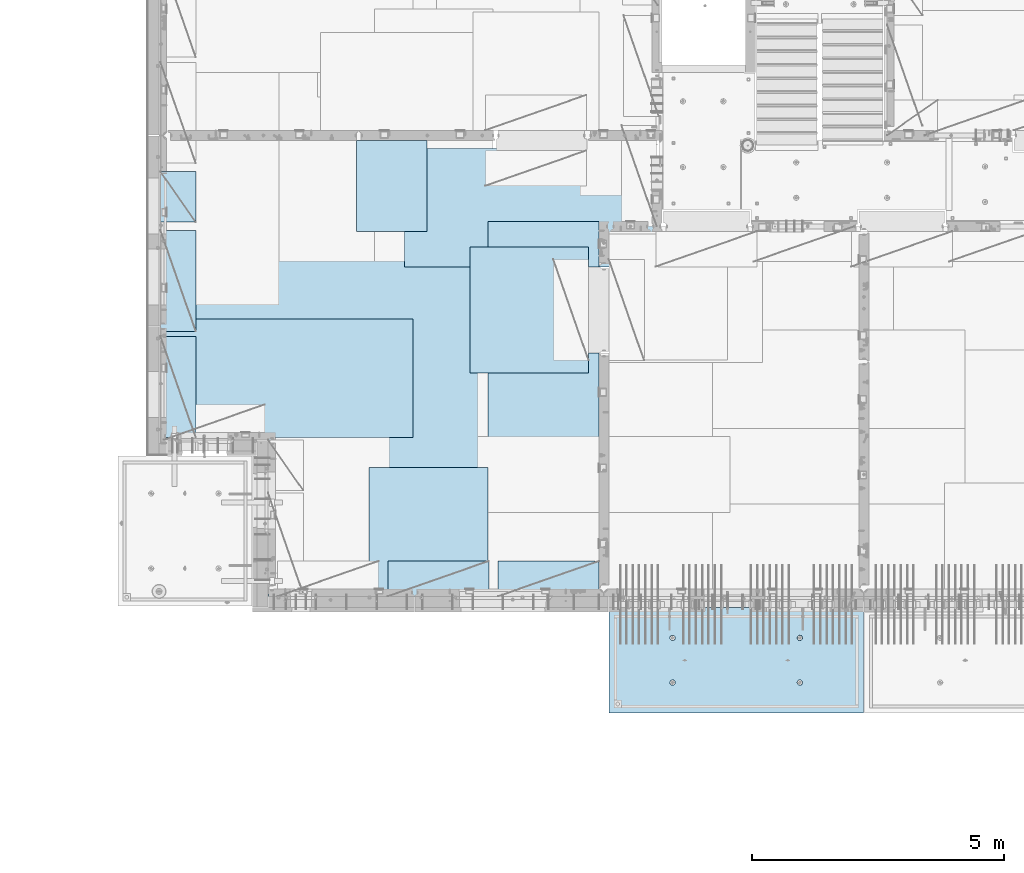
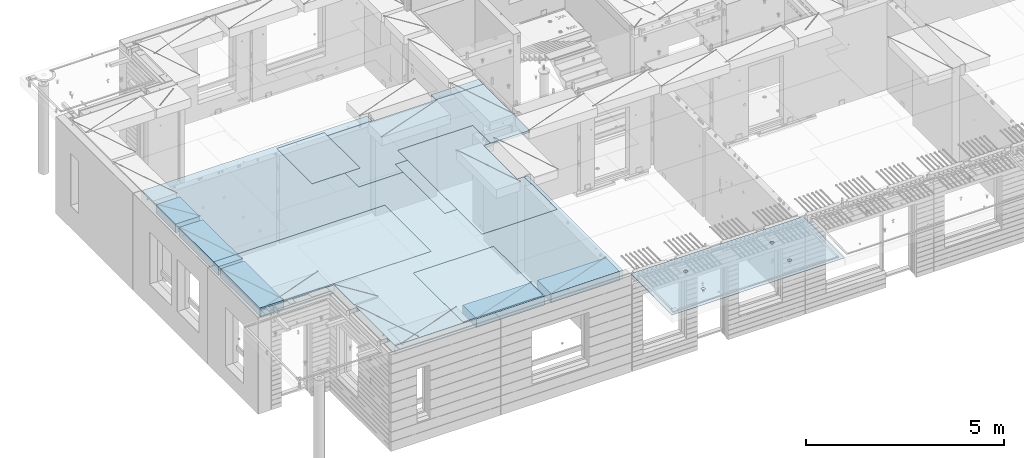
# One storey, part 199 of 352: 11 plates, 2 slabs, 11 elements without a shape of their own.
"""IFC2X3 building model written with IfcOpenShell, lengths in millimetres."""

import ifcopenshell
import ifcopenshell.guid

model = None  # the IFC model being written
_history = None  # IfcOwnerHistory: only IFC2X3 demands one
_inside = {}  # id of a spatial element -> (the spatial element, [elements in it])
_under = {}  # id of a project, library or spatial element -> (it, [spatial elements below it])
_declared = {}  # id of a project -> (the project, [libraries it declares])
_typed = {}  # id of a type object -> (the type object, [elements of that type])
_made_of = {}  # id of a material, layer set ... -> (it, [elements and type objects made of it])


def new_model(schema):
    """Start an empty IFC model of exactly this schema.

    Asked for "IFC4X3", IfcOpenShell would pick the latest addendum, in which some entities
    have other attributes; the version numbers below select the first issue.
    IFC2X3 requires an IfcOwnerHistory on every rooted entity: one is made here for all.
    """
    global model, _history
    if schema == "IFC4X3":
        model = ifcopenshell.file(schema_version=(4, 3, 0, 0))
    else:
        model = ifcopenshell.file(schema=schema)
    _inside.clear()
    _under.clear()
    _declared.clear()
    _typed.clear()
    _made_of.clear()
    _history = None
    if model.schema == "IFC2X3":
        org = make("IfcOrganization", Name="unknown")
        user = make(
            "IfcPersonAndOrganization",
            ThePerson=make("IfcPerson", FamilyName="unknown"),
            TheOrganization=org,
        )
        app = make(
            "IfcApplication",
            ApplicationDeveloper=org,
            Version="unknown",
            ApplicationFullName="unknown",
            ApplicationIdentifier="unknown",
        )
        _history = make(
            "IfcOwnerHistory",
            OwningUser=user,
            OwningApplication=app,
            ChangeAction="ADDED",
            CreationDate=0,
        )
    return model


def make(cls, **values):
    """One entity of the class cls with the attributes given. An attribute that is None is left unset."""
    return model.create_entity(
        cls, **{name: value for name, value in values.items() if value is not None}
    )


def rooted(cls, **values):
    """An entity with a GlobalId (a new one), such as an element, a storey or a relation."""
    return make(cls, GlobalId=ifcopenshell.guid.new(), OwnerHistory=_history, **values)


def si_unit(unit_type, name, prefix=None):
    """IfcSIUnit, for example si_unit("LENGTHUNIT", "METRE", prefix="MILLI")."""
    return make("IfcSIUnit", UnitType=unit_type, Prefix=prefix, Name=name)


def assignment(units):
    """IfcUnitAssignment: the units of a project."""
    return None if units is None else make("IfcUnitAssignment", Units=units)


def point(xyz):
    """IfcCartesianPoint."""
    return None if xyz is None else make("IfcCartesianPoint", Coordinates=xyz)


def direction(xyz):
    """IfcDirection."""
    return None if xyz is None else make("IfcDirection", DirectionRatios=xyz)


def frame(location, z_axis=None, x_axis=None):
    """IfcAxis2Placement3D, a coordinate frame: its origin and axes. An axis left out is left unset."""
    return make(
        "IfcAxis2Placement3D",
        Location=point(location),
        Axis=direction(z_axis),
        RefDirection=direction(x_axis),
    )


def origin_with_axes():
    """The frame at (0, 0, 0) with the z axis (0, 0, 1) and the x axis (1, 0, 0) written out."""
    return frame((0.0, 0.0, 0.0), z_axis=(0.0, 0.0, 1.0), x_axis=(1.0, 0.0, 0.0))


def place(relative_to, where):
    """IfcLocalPlacement: puts the frame where relative to a parent placement (None: the world)."""
    return make(
        "IfcLocalPlacement", PlacementRelTo=relative_to, RelativePlacement=where
    )


def context(
    kind, dimensions, precision=None, world=None, true_north=None, identifier=None
):
    """IfcGeometricRepresentationContext, for example the 3D "Model" context."""
    return make(
        "IfcGeometricRepresentationContext",
        ContextIdentifier=identifier,
        ContextType=kind,
        CoordinateSpaceDimension=dimensions,
        Precision=precision,
        WorldCoordinateSystem=world,
        TrueNorth=true_north,
    )


def subcontext(parent, identifier, kind, view, scale=None):
    """IfcGeometricRepresentationSubContext, for example "Body" below "Model"."""
    return make(
        "IfcGeometricRepresentationSubContext",
        ContextIdentifier=identifier,
        ContextType=kind,
        ParentContext=parent,
        TargetScale=scale,
        TargetView=view,
    )


def project(units=None, contexts=None):
    """IfcProject with its units and contexts."""
    return rooted(
        "IfcProject",
        Name="project",
        RepresentationContexts=contexts,
        UnitsInContext=assignment(units),
    )


def spatial(cls, under=None, at=None, **own):
    """A site, building, storey or space (cls), placed at a placement, below another one or the project."""
    s = rooted(cls, ObjectPlacement=at, **own)
    if under is not None:
        _under.setdefault(under.id(), (under, []))[1].append(s)
    return s


def faces_of(points, faces, orient=None, outer=None):
    """IfcFace entities. A face is a list of loops; a loop is a list of indices into points, from 0.

    orient and outer hold one flag for each loop. By default every Orientation is true, the
    first loop of a face is its IfcFaceOuterBound and the others are IfcFaceBound.
    """
    made = []
    for i, loops in enumerate(faces):
        bounds = []
        for j, loop in enumerate(loops):
            is_outer = j == 0 if outer is None else outer[i][j]
            bounds.append(
                make(
                    "IfcFaceOuterBound" if is_outer else "IfcFaceBound",
                    Bound=make("IfcPolyLoop", Polygon=[points[k] for k in loop]),
                    Orientation=True if orient is None else orient[i][j],
                )
            )
        made.append(make("IfcFace", Bounds=bounds))
    return made


def faceted_brep(points, faces, orient=None, outer=None, voids=None):
    """IfcFacetedBrep: a solid bounded by flat faces; with voids (closed shells), ...WithVoids."""
    shared = [point(p) for p in points]
    hull = make("IfcClosedShell", CfsFaces=faces_of(shared, faces, orient, outer))
    if voids is None:
        return make("IfcFacetedBrep", Outer=hull)
    return make(
        "IfcFacetedBrepWithVoids",
        Outer=hull,
        Voids=[
            make(cls, CfsFaces=faces_of(shared, fs, o, b)) for cls, fs, o, b in voids
        ],
    )


def shape(context_of_items, identifier, shape_type, items):
    """IfcShapeRepresentation: the items that make up one representation, for example the "Body"."""
    return make(
        "IfcShapeRepresentation",
        ContextOfItems=context_of_items,
        RepresentationIdentifier=identifier,
        RepresentationType=shape_type,
        Items=items,
    )


def material(Name=None, Category=None):
    """IfcMaterial."""
    return make("IfcMaterial", Name=Name, Category=Category)


def made_of(thing, what):
    """Note that an element or type object is made of a material, layer set ...; save() writes the relation."""
    if what is not None:
        _made_of.setdefault(what.id(), (what, []))[1].append(thing)
    return thing


def type_object(cls, material=None, **own):
    """A type object (cls), such as IfcWallType, which elements share."""
    return made_of(rooted(cls, **own), material)


def element(
    cls,
    number,
    at=None,
    inside=None,
    cuts=None,
    type_object=None,
    material=None,
    context=None,
    identifier="Body",
    shape_type=None,
    held_by="IfcProductDefinitionShape",
    body=None,
    shapes=None,
    **own,
):
    """One element of the class cls, such as IfcWall. Its Tag is "e" and its number.

    at: its placement. inside: the storey or other place that contains it. cuts: it is an
    opening in that element (IfcRelVoidsElement). A single representation is given by context,
    identifier, shape_type and body (its items); several are given by shapes. held_by: the class
    of the entity that holds the representations. save() writes the other relations.
    """
    e = rooted(cls, Tag="e%d" % number, ObjectPlacement=at, **own)
    if body is not None:
        shapes = [shape(context, identifier, shape_type, body)]
    if shapes is not None:
        e.Representation = make(held_by, Representations=shapes)
    if inside is not None:
        _inside.setdefault(inside.id(), (inside, []))[1].append(e)
    if cuts is not None:
        rooted(
            "IfcRelVoidsElement", RelatingBuildingElement=cuts, RelatedOpeningElement=e
        )
    if type_object is not None:
        _typed.setdefault(type_object.id(), (type_object, []))[1].append(e)
    return made_of(e, material)


def aggregate(whole, parts):
    """IfcRelAggregates: a whole, such as a stair, and the parts it consists of."""
    return rooted("IfcRelAggregates", RelatingObject=whole, RelatedObjects=parts)


def save(model, path):
    """Write the relations noted so far, then the file.

    IfcRelAggregates (storeys below a building ...), IfcRelContainedInSpatialStructure (elements
    in a storey), IfcRelDefinesByType, IfcRelAssociatesMaterial and IfcRelDeclares: one each for
    every whole, place, type object, material and project.
    """
    for whole, parts in _under.values():
        aggregate(whole, parts)
    for where, things in _inside.values():
        rooted(
            "IfcRelContainedInSpatialStructure",
            RelatedElements=things,
            RelatingStructure=where,
        )
    for kind, things in _typed.values():
        rooted("IfcRelDefinesByType", RelatedObjects=things, RelatingType=kind)
    for what, things in _made_of.values():
        rooted("IfcRelAssociatesMaterial", RelatedObjects=things, RelatingMaterial=what)
    for by, libraries in _declared.values():
        rooted("IfcRelDeclares", RelatingContext=by, RelatedDefinitions=libraries)
    model.write(path)


model = new_model("IFC2X3")

# Units and contexts
model_context = context("Model", 3, precision=1e-05, world=origin_with_axes())
body_context = subcontext(model_context, "Body", "Model", "MODEL_VIEW")
ifc_project = project(units=[si_unit("LENGTHUNIT", "METRE", prefix="MILLI"), si_unit("AREAUNIT", "SQUARE_METRE"), si_unit("VOLUMEUNIT", "CUBIC_METRE"), si_unit("MASSUNIT", "GRAM", prefix="KILO"), si_unit("TIMEUNIT", "SECOND"), si_unit("PLANEANGLEUNIT", "RADIAN"), si_unit("SOLIDANGLEUNIT", "STERADIAN"), si_unit("THERMODYNAMICTEMPERATUREUNIT", "DEGREE_CELSIUS"), si_unit("LUMINOUSINTENSITYUNIT", "LUMEN")], contexts=[model_context])

# Site, building, storey
site_placement = place(None, origin_with_axes())
site = spatial("IfcSite", under=ifc_project, at=site_placement, CompositionType="ELEMENT")
building_placement = place(site_placement, origin_with_axes())
building = spatial("IfcBuilding", under=site, at=building_placement, CompositionType="ELEMENT")
storey_placement = place(building_placement, origin_with_axes())
storey = spatial("IfcBuildingStorey", under=building, at=storey_placement, Name="6", CompositionType="ELEMENT", Elevation=0.0)

# Assembly, slab
assembly_1_placement = place(storey_placement, origin_with_axes())
assembly_1 = element("IfcElementAssembly", 1, at=assembly_1_placement, inside=storey, AssemblyPlace="NOTDEFINED", PredefinedType="REINFORCEMENT_UNIT")
ifc_material_1 = material(Name="CONCRETE/C35/45")
slab_type_1 = type_object("IfcSlabType", PredefinedType="NOTDEFINED")
slab_1_placement = place(assembly_1_placement, frame((21799.9998568133, 7629.99655735226, 99720.0), z_axis=(-1.11800000013248e-06, -0.999999999999375, 0.0), x_axis=(-0.999999999999093, 1.34699999998405e-06, 0.0)))
slab_1 = element("IfcSlab", 2, at=slab_1_placement, type_object=slab_type_1, material=ifc_material_1, PredefinedType="FLOOR", context=body_context, shape_type="Brep", body=[
    faceted_brep([(3730.38290548735, -4.08996566387941, 616.12216176429), (3731.90567362447, 10.0, 615.627386703446), (3739.08833473806, 10.0, 629.724200466487), (3737.80580686752, -3.95055250760925, 630.656008831066), (3750.27560641379, 10.0, 640.911502705889), (3749.35118053074, -3.83997377335618, 642.183862123165), (3764.37240055375, 10.0, 648.094202331947), (3763.88889206625, -3.76900584615942, 649.582281527485), (3779.99882472937, 10.0, 650.569206660445), (3779.99882259584, -3.74455690493051, 652.131088126915), (3795.62525566664, 10.0, 648.094245023346), (3796.1087600739, -3.76900542440126, 649.582325494244), (3809.72206942968, 10.0, 640.911583909758), (3810.64649178305, -3.83997297089081, 642.183945778786), (3820.90937166908, 10.0, 629.724312234022), (3822.19189689232, -3.95055140258046, 630.656124028656), (3828.09207129514, 10.0, 615.627518094066), (3829.61483794004, -4.08996436404414, 616.122297269464), (3830.56707562364, 10.0, 600.001093918447), (3832.18578061358, -4.24460391153116, 600.001096129598), (3828.09211398654, 10.0, 584.374662981175), (3829.64831848373, -4.39934773846471, 583.869023838871), (3820.90945287295, 10.0, 570.277849218135), (3822.24608208202, -4.53903372617788, 569.306734043194), (3809.72218119721, 10.0, 559.090546978732), (3810.70070853473, -4.64994969953841, 557.743723511573), (3795.62538705726, 10.0, 551.907847352675), (3796.14233218844, -4.72119045964791, 550.316861227655), (3779.99896288164, 10.0, 549.432843024176), (3779.99896517058, -4.74574361447594, 547.757190340714), (3764.37253194437, 10.0, 551.907804661275), (3763.85559114489, -4.72119088313775, 550.316817078197), (3750.27571818133, 10.0, 559.090465774863), (3749.29719446955, -4.6499505048414, 557.743639560339), (3739.08841594193, 10.0, 570.277737450599), (3737.75178928409, -4.53903483404429, 569.306618549992), (3731.90571631587, 10.0, 584.374531590555), (3730.34951305942, -4.39934904004622, 583.868888150996), (3729.43071198737, 10.0, 600.000955766174), (3727.81200684201, -4.24460527917836, 600.000953555023), (0.0, 10.0, 0.0), (0.0, -10.0, 0.0), (0.000328360383718973, 10.0, 2085.00366210938), (5040.0, 10.0, -2.18278728425503e-09), (5040.0, -10.0, -2.18278728425503e-09), (5040.00048828125, 10.0, 2085.00366210938), (1210.18496592851, 4.0893025782425, 1468.8123736889), (1210.82376192895, 10.0, 1469.01993205604), (1208.29313952565, 10.0, 1484.99751183111), (1207.63911173254, 4.24455542066426, 1484.99751093771), (1217.61159442581, 3.94915724093153, 1454.20219661341), (1218.16787053537, 10.0, 1454.6063560253), (1229.19498209749, 3.837876675796, 1442.60117732261), (1229.60657282509, 10.0, 1443.16768498606), (1243.80127350603, 3.76640192835475, 1435.14992181469), (1244.02016891989, 10.0, 1435.82361575756), (1259.99775658, 3.74176842256566, 1432.58187432577), (1259.99775560856, 10.0, 1433.29303700502), (1276.19423262309, 3.76640235324157, 1435.14996610939), (1275.97533538363, 10.0, 1435.82365940832), (1290.8005036357, 3.83787748374743, 1442.60126155003), (1290.38891141437, 10.0, 1443.16776801473), (1302.38385956513, 3.94915835243592, 1454.20231248656), (1301.82758245361, 10.0, 1454.60647030446), (1309.81044810845, 4.08930388411682, 1468.81250982317), (1309.17165168211, 10.0, 1469.02006639926), (1312.35625807182, 4.244556792808, 1484.99765398133), (1311.70223043464, 10.0, 1484.99765308793), (1309.77685741928, 4.39970507899125, 1501.17189122433), (1309.17160803135, 10.0, 1500.975232863), (1302.32949611505, 4.53957668620569, 1515.75353188573), (1301.82749942493, 10.0, 1515.38880889374), (1290.74610851982, 4.65051890275208, 1527.31927827547), (1290.3887971352, 10.0, 1526.82747993297), (1276.16055006181, 4.72171992080985, 1534.74199744468), (1275.97520104041, 10.0, 1534.17154916147), (1259.99761353621, 4.74624887190294, 1537.29914508766), (1259.99761435174, 10.0, 1536.70212791401), (1243.83468398195, 4.72171949766926, 1534.74195333328), (1244.02003457667, 10.0, 1534.17150551072), (1229.24914576394, 4.65051809765282, 1527.31919434463), (1229.60645854592, 10.0, 1526.8273969043), (1217.66578971822, 4.53957557752437, 1515.75341630916), (1218.16778750669, 10.0, 1515.38869461457), (1210.21846821205, 4.39970377489226, 1501.17175527336), (1210.82371827819, 10.0, 1500.97509851978), (1210.34950957413, -4.39938207223895, 583.86544460908), (1211.90571640051, 10.0, 584.371089208588), (1209.43071207202, 10.0, 599.997513384207), (1207.81200317426, -4.24463830025343, 599.997511173051), (1217.75178633104, -4.53906787629239, 569.303173961003), (1219.08841602657, 10.0, 570.274295068632), (1229.29719234665, -4.64998355506395, 557.740194139937), (1230.27571826597, 10.0, 559.087023392896), (1243.85559006878, -4.72122393849713, 550.313371123784), (1244.37253202901, 10.0, 551.904362279308), (1259.99896525523, -4.74577667158155, 547.753744202259), (1259.99896296629, 10.0, 549.429400642209), (1276.14233343384, -4.72122351497819, 550.313415273247), (1275.6253871419, 10.0, 551.904404970708), (1290.70071082692, -4.64998274977552, 557.740278091178), (1289.72218128186, 10.0, 559.087104596765), (1302.24608520437, -4.53906676842598, 569.303289454215), (1300.9094529576, 10.0, 570.274406836168), (1309.64832213832, -4.39938077065744, 583.865580296964), (1308.09211407118, 10.0, 584.371220599208), (1312.18578445062, -4.24463693260623, 599.997653747636), (1310.56707570828, 10.0, 599.99765153648), (1309.61484159223, -4.08999737400154, 616.118856046664), (1308.09207137979, 10.0, 615.624075712099), (1302.19190001076, -3.95058440251159, 630.652683850883), (1300.90937175373, 10.0, 629.720869852055), (1290.64649407134, -3.8400059628766, 642.180506429899), (1289.72206951433, 10.0, 640.908141527791), (1276.10876131689, -3.76903841129388, 649.578886677323), (1275.62525575129, 10.0, 648.090802641378), (1259.99882268048, -3.74458989004779, 652.127649493255), (1259.99882481401, 10.0, 650.565764278478), (1243.88889099253, -3.76903883303748, 649.578842710559), (1244.37240063839, 10.0, 648.090759949978), (1229.35117841172, -3.84000676534197, 642.180422774271), (1230.27560649844, 10.0, 640.908060323922), (1217.80580391836, -3.95058550754038, 630.652568653284), (1219.0883348227, 10.0, 629.72075808452), (1210.38290200446, -4.08999867383682, 616.11872054148), (1211.90567370912, 10.0, 615.623944321479), (3795.97520095576, 10.0, 1534.17499154344), (3796.16054881881, 4.72175290768791, 1534.7454362616), (3779.99761345157, 4.74628185702022, 1537.30258372132), (3779.99761426709, 10.0, 1536.70557029598), (3810.38879705055, 10.0, 1526.83092231494), (3810.74610623151, 4.65055189473787, 1527.32271762435), (3821.82749934028, 10.0, 1515.39225127571), (3822.3294929966, 4.53960968612228, 1515.75697206351), (3829.1716079467, 10.0, 1500.97867524496), (3829.7768537671, 4.39973808894865, 1501.17533244712), (3831.70223035, 10.0, 1485.00109546989), (3832.35625423479, 4.24458981388307, 1485.00109636329), (3829.17165159746, 10.0, 1469.02350878122), (3829.81044445387, 4.08933691630955, 1468.81595336508), (3821.82758236896, 10.0, 1454.60991268643), (3822.38385644279, 3.94919139468402, 1454.20575707554), (3810.38891132972, 10.0, 1443.1712103967), (3810.8005013435, 3.83791053396999, 1442.60470697043), (3795.97533529899, 10.0, 1435.82710179029), (3796.19423137769, 3.76643540860096, 1435.1534120638), (3779.99775552391, 10.0, 1433.29647938699), (3779.99775649536, 3.74180147968582, 1432.58532046422), (3764.02016883524, 10.0, 1435.82705813953), (3763.80127458214, 3.76643498368503, 1435.1533677691), (3749.60657274045, 10.0, 1443.17112736803), (3749.19498422039, 3.837909726004, 1442.60462274301), (3738.16787045072, 10.0, 1454.60979840726), (3737.61159737886, 3.94919028317963, 1454.2056412024), (3730.82376184431, 10.0, 1469.023374438), (3730.18496941381, 4.08933561044978, 1468.81581723082), (3737.66579266739, 4.53960857747006, 1515.75685648694), (3749.24914788297, 4.65055108962406, 1527.32263369353), (3763.83468505566, 4.72175248454732, 1534.7453921502), (3727.63911540029, 4.24458844172477, 1485.00095331968), (3730.21847169495, 4.39973678484967, 1501.17519649617), (3764.02003449202, 10.0, 1534.17494789268), (3749.60645846128, 10.0, 1526.83083928627), (3738.16778742204, 10.0, 1515.39213699654), (3730.82371819355, 10.0, 1500.97854090175), (3728.293139441, 10.0, 1485.00095421308)], [[[0, 1, 2, 3]], [[3, 2, 4, 5]], [[5, 4, 6, 7]], [[7, 6, 8, 9]], [[10, 11, 9, 8]], [[12, 13, 11, 10]], [[14, 15, 13, 12]], [[16, 17, 15, 14]], [[18, 19, 17, 16]], [[20, 21, 19, 18]], [[22, 23, 21, 20]], [[24, 25, 23, 22]], [[26, 27, 25, 24]], [[27, 26, 28, 29]], [[29, 28, 30, 31]], [[31, 30, 32, 33]], [[33, 32, 34, 35]], [[35, 34, 36, 37]], [[37, 36, 38, 39]], [[39, 38, 1, 0]], [[40, 41, 42]], [[40, 43, 44, 41]], [[43, 45, 44]], [[46, 47, 48, 49]], [[50, 51, 47, 46]], [[52, 53, 51, 50]], [[54, 55, 53, 52]], [[56, 57, 55, 54]], [[58, 59, 57, 56]], [[60, 61, 59, 58]], [[61, 60, 62, 63]], [[63, 62, 64, 65]], [[65, 64, 66, 67]], [[67, 66, 68, 69]], [[69, 68, 70, 71]], [[71, 70, 72, 73]], [[73, 72, 74, 75]], [[75, 74, 76, 77]], [[77, 76, 78, 79]], [[80, 81, 79, 78]], [[82, 83, 81, 80]], [[84, 85, 83, 82]], [[49, 48, 85, 84]], [[86, 87, 88, 89]], [[90, 91, 87, 86]], [[92, 93, 91, 90]], [[94, 95, 93, 92]], [[96, 97, 95, 94]], [[98, 99, 97, 96]], [[99, 98, 100, 101]], [[101, 100, 102, 103]], [[103, 102, 104, 105]], [[105, 104, 106, 107]], [[107, 106, 108, 109]], [[109, 108, 110, 111]], [[111, 110, 112, 113]], [[113, 112, 114, 115]], [[115, 114, 116, 117]], [[118, 119, 117, 116]], [[120, 121, 119, 118]], [[122, 123, 121, 120]], [[124, 125, 123, 122]], [[89, 88, 125, 124]], [[126, 127, 128, 129]], [[130, 131, 127, 126]], [[132, 133, 131, 130]], [[134, 135, 133, 132]], [[136, 137, 135, 134]], [[138, 139, 137, 136]], [[140, 141, 139, 138]], [[142, 143, 141, 140]], [[143, 142, 144, 145]], [[145, 144, 146, 147]], [[147, 146, 148, 149]], [[149, 148, 150, 151]], [[151, 150, 152, 153]], [[153, 152, 154, 155]], [[41, 44, 45, 42], [3, 5, 7, 9, 11, 13, 15, 17, 19, 21, 23, 25, 27, 29, 31, 33, 35, 37, 39, 0], [156, 157, 158, 128, 127, 131, 133, 135, 137, 139, 141, 143, 145, 147, 149, 151, 153, 155, 159, 160], [122, 120, 118, 116, 114, 112, 110, 108, 106, 104, 102, 100, 98, 96, 94, 92, 90, 86, 89, 124], [82, 80, 78, 76, 74, 72, 70, 68, 66, 64, 62, 60, 58, 56, 54, 52, 50, 46, 49, 84]], [[129, 128, 158, 161]], [[157, 162, 161, 158]], [[156, 163, 162, 157]], [[160, 164, 163, 156]], [[159, 165, 164, 160]], [[155, 154, 165, 159]], [[43, 40, 42, 45], [34, 32, 30, 28, 26, 24, 22, 20, 18, 16, 14, 12, 10, 8, 6, 4, 2, 1, 38, 36], [152, 150, 148, 146, 144, 142, 140, 138, 136, 134, 132, 130, 126, 129, 161, 162, 163, 164, 165, 154], [91, 93, 95, 97, 99, 101, 103, 105, 107, 109, 111, 113, 115, 117, 119, 121, 123, 125, 88, 87], [51, 53, 55, 57, 59, 61, 63, 65, 67, 69, 71, 73, 75, 77, 79, 81, 83, 85, 48, 47]]]),
])
aggregate(assembly_1, [slab_1])

# Assembly, plate
assembly_2_placement = place(storey_placement, origin_with_axes())
assembly_2 = element("IfcElementAssembly", 3, at=assembly_2_placement, inside=storey, Name="Steel Assembly", AssemblyPlace="NOTDEFINED", PredefinedType="NOTDEFINED")
ifc_material_2 = material()
plate_type_1 = type_object("IfcPlateType", PredefinedType="NOTDEFINED")
plate_1_placement = place(assembly_2_placement, frame((14009.7695320312, 12275.0000289158, 99695.1), z_axis=(0.0, 1.0, 0.0), x_axis=(1.0, 0.0, 0.0)))
plate_1 = element("IfcPlate", 4, at=plate_1_placement, type_object=plate_type_1, material=ifc_material_2, Name="1/2", context=body_context, shape_type="Brep", body=[
    faceted_brep([(0.0, -35.0, 0.0), (0.0, -35.0, 2500.0), (0.0, 35.0, 2500.0), (0.0, 35.0, 0.0), (2349.99951171875, -35.0, 2500.0), (2349.99951171875, 35.0, 2500.0), (2350.0, -35.0, 0.0), (2350.0, 35.0, 0.0)], [[[0, 1, 2, 3]], [[1, 4, 5, 2]], [[4, 6, 7, 5]], [[6, 0, 3, 7]], [[5, 7, 3, 2]], [[6, 4, 1, 0]]]),
])
aggregate(assembly_2, [plate_1])

assembly_3_placement = place(storey_placement, origin_with_axes())
assembly_3 = element("IfcElementAssembly", 5, at=assembly_3_placement, inside=storey, Name="Steel Assembly", AssemblyPlace="NOTDEFINED", PredefinedType="NOTDEFINED")
plate_2_placement = place(assembly_3_placement, frame((14360.0, 10400.0, 99695.1), z_axis=(0.0, -1.0, 0.0), x_axis=(-1.0, 3.00000001838171e-08, 0.0)))
plate_2 = element("IfcPlate", 6, at=plate_2_placement, type_object=plate_type_1, material=ifc_material_2, Name="1/2", context=body_context, shape_type="Brep", body=[
    faceted_brep([(0.0, -35.0, 0.0), (0.0, -35.0, 2500.0), (0.0, 35.0, 2500.0), (0.0, 35.0, 0.0), (2349.99951171875, -35.0, 2500.0), (2349.99951171875, 35.0, 2500.0), (2350.0, -35.0, 0.0), (2350.0, 35.0, 0.0)], [[[0, 1, 2, 3]], [[1, 4, 5, 2]], [[4, 6, 7, 5]], [[6, 0, 3, 7]], [[5, 7, 3, 2]], [[6, 4, 1, 0]]]),
])
aggregate(assembly_3, [plate_2])

assembly_4_placement = place(storey_placement, origin_with_axes())
assembly_4 = element("IfcElementAssembly", 7, at=assembly_4_placement, inside=storey, Name="Steel Assembly", AssemblyPlace="NOTDEFINED", PredefinedType="NOTDEFINED")
plate_3_placement = place(assembly_4_placement, frame((12710.0, 16725.0, 99695.1), z_axis=(1.0, 0.0, 0.0), x_axis=(0.0, -1.0, 0.0)))
plate_3 = element("IfcPlate", 8, at=plate_3_placement, type_object=plate_type_1, material=ifc_material_2, context=body_context, shape_type="Brep", body=[
    faceted_brep([(0.0, -35.0, 0.0), (0.0, -35.0, 5000.0), (0.0, 35.0, 5000.0), (0.0, 35.0, 0.0), (2349.99951171875, -35.0, 5000.0), (2349.99951171875, 35.0, 5000.0), (2350.0, -35.0, 0.0), (2350.0, 35.0, 0.0)], [[[0, 1, 2, 3]], [[1, 4, 5, 2]], [[4, 6, 7, 5]], [[6, 0, 3, 7]], [[5, 7, 3, 2]], [[6, 4, 1, 0]]]),
])
aggregate(assembly_4, [plate_3])

assembly_5_placement = place(storey_placement, origin_with_axes())
assembly_5 = element("IfcElementAssembly", 9, at=assembly_5_placement, inside=storey, Name="Steel Assembly", AssemblyPlace="NOTDEFINED", PredefinedType="NOTDEFINED")
plate_4_placement = place(assembly_5_placement, frame((12880.0, 11000.0, 99695.1), z_axis=(-1.0, 3.00000001838171e-08, 0.0), x_axis=(0.0, 1.0, 0.0)))
plate_4 = element("IfcPlate", 10, at=plate_4_placement, type_object=plate_type_1, material=ifc_material_2, context=body_context, shape_type="Brep", body=[
    faceted_brep([(0.0, -35.0, 0.0), (0.0, -35.0, 5000.0), (0.0, 35.0, 5000.0), (0.0, 35.0, 0.0), (2349.99951171875, -35.0, 5000.0), (2349.99951171875, 35.0, 5000.0), (2350.0, -35.0, 0.0), (2350.0, 35.0, 0.0)], [[[0, 1, 2, 3]], [[1, 4, 5, 2]], [[4, 6, 7, 5]], [[6, 0, 3, 7]], [[5, 7, 3, 2]], [[6, 4, 1, 0]]]),
])
aggregate(assembly_5, [plate_4])

assembly_6_placement = place(storey_placement, origin_with_axes())
assembly_6 = element("IfcElementAssembly", 11, at=assembly_6_placement, inside=storey, Name="Steel Assembly", AssemblyPlace="NOTDEFINED", PredefinedType="NOTDEFINED")
plate_type_2 = type_object("IfcPlateType", PredefinedType="NOTDEFINED")
plate_5_placement = place(assembly_6_placement, frame((7879.99987792969, 13000.0, 99595.3), z_axis=(1.0, 0.0, 0.0), x_axis=(0.0, -1.0, 0.0)))
plate_5 = element("IfcPlate", 12, at=plate_5_placement, type_object=plate_type_2, material=ifc_material_2, Name="RE1", context=body_context, shape_type="Brep", body=[
    faceted_brep([(1.81898940354586e-12, -135.0, 1.81898940354586e-12), (0.0, -135.0, 699.999999999996), (0.0, 135.0, 699.999999999996), (1.81898940354586e-12, 135.0, 1.81898940354586e-12), (1999.99951171875, -135.0, 699.999999999993), (1999.99951171875, 135.0, 699.999999999993), (2000.0, -135.0, -3.63797880709171e-12), (2000.0, 135.0, -3.63797880709171e-12)], [[[0, 1, 2, 3]], [[1, 4, 5, 2]], [[4, 6, 7, 5]], [[6, 0, 3, 7]], [[5, 7, 3, 2]], [[6, 4, 1, 0]]]),
])
aggregate(assembly_6, [plate_5])

assembly_7_placement = place(storey_placement, origin_with_axes())
assembly_7 = element("IfcElementAssembly", 13, at=assembly_7_placement, inside=storey, Name="Steel Assembly", AssemblyPlace="NOTDEFINED", PredefinedType="NOTDEFINED")
plate_6_placement = place(assembly_7_placement, frame((7879.99999992931, 16265.0, 99595.3), z_axis=(1.0, 0.0, 0.0), x_axis=(0.0, -1.0, 0.0)))
plate_6 = element("IfcPlate", 14, at=plate_6_placement, type_object=plate_type_2, material=ifc_material_2, Name="RE1_1/2", context=body_context, shape_type="Brep", body=[
    faceted_brep([(1.81898940354586e-12, -135.0, 1.81898940354586e-12), (0.0, -135.0, 699.999999999996), (0.0, 135.0, 699.999999999996), (1.81898940354586e-12, 135.0, 1.81898940354586e-12), (999.99951171875, -135.0, 700.0), (999.99951171875, 135.0, 700.0), (1000.0, -135.0, 0.0), (1000.0, 135.0, 0.0)], [[[0, 1, 2, 3]], [[1, 4, 5, 2]], [[4, 6, 7, 5]], [[6, 0, 3, 7]], [[5, 7, 3, 2]], [[6, 4, 1, 0]]]),
])
aggregate(assembly_7, [plate_6])

assembly_8_placement = place(storey_placement, origin_with_axes())
assembly_8 = element("IfcElementAssembly", 15, at=assembly_8_placement, inside=storey, Name="Steel Assembly", AssemblyPlace="NOTDEFINED", PredefinedType="NOTDEFINED")
plate_7_placement = place(assembly_8_placement, frame((14565.0008542386, 7850.00010363356, 99595.3), z_axis=(0.0, 1.0, 0.0), x_axis=(1.0, 0.0, 0.0)))
plate_7 = element("IfcPlate", 16, at=plate_7_placement, type_object=plate_type_2, material=ifc_material_2, Name="RE1", context=body_context, shape_type="Brep", body=[
    faceted_brep([(1.81898940354586e-12, -135.0, 1.81898940354586e-12), (0.0, -135.0, 699.999999999996), (0.0, 135.0, 699.999999999996), (1.81898940354586e-12, 135.0, 1.81898940354586e-12), (1999.99951171875, -135.0, 699.999999999993), (1999.99951171875, 135.0, 699.999999999993), (2000.0, -135.0, -3.63797880709171e-12), (2000.0, 135.0, -3.63797880709171e-12)], [[[0, 1, 2, 3]], [[1, 4, 5, 2]], [[4, 6, 7, 5]], [[6, 0, 3, 7]], [[5, 7, 3, 2]], [[6, 4, 1, 0]]]),
])
aggregate(assembly_8, [plate_7])

assembly_9_placement = place(storey_placement, origin_with_axes())
assembly_9 = element("IfcElementAssembly", 17, at=assembly_9_placement, inside=storey, Name="Steel Assembly", AssemblyPlace="NOTDEFINED", PredefinedType="NOTDEFINED")
plate_8_placement = place(assembly_9_placement, frame((12382.5008542386, 7850.00010363356, 99595.3), z_axis=(0.0, 1.0, 0.0), x_axis=(1.0, 0.0, 0.0)))
plate_8 = element("IfcPlate", 18, at=plate_8_placement, type_object=plate_type_2, material=ifc_material_2, Name="RE1", context=body_context, shape_type="Brep", body=[
    faceted_brep([(1.81898940354586e-12, -135.0, 1.81898940354586e-12), (0.0, -135.0, 699.999999999996), (0.0, 135.0, 699.999999999996), (1.81898940354586e-12, 135.0, 1.81898940354586e-12), (1999.99951171875, -135.0, 699.999999999993), (1999.99951171875, 135.0, 699.999999999993), (2000.0, -135.0, -3.63797880709171e-12), (2000.0, 135.0, -3.63797880709171e-12)], [[[0, 1, 2, 3]], [[1, 4, 5, 2]], [[4, 6, 7, 5]], [[6, 0, 3, 7]], [[5, 7, 3, 2]], [[6, 4, 1, 0]]]),
])
aggregate(assembly_9, [plate_8])

assembly_10_placement = place(storey_placement, origin_with_axes())
assembly_10 = element("IfcElementAssembly", 19, at=assembly_10_placement, inside=storey, Name="Steel Assembly", AssemblyPlace="NOTDEFINED", PredefinedType="NOTDEFINED")
plate_9_placement = place(assembly_10_placement, frame((7879.99987792969, 15100.0, 99595.3), z_axis=(1.0, 0.0, 0.0), x_axis=(0.0, -1.0, 0.0)))
plate_9 = element("IfcPlate", 20, at=plate_9_placement, type_object=plate_type_2, material=ifc_material_2, Name="RE1", context=body_context, shape_type="Brep", body=[
    faceted_brep([(1.81898940354586e-12, -135.0, 1.81898940354586e-12), (0.0, -135.0, 699.999999999996), (0.0, 135.0, 699.999999999996), (1.81898940354586e-12, 135.0, 1.81898940354586e-12), (1999.99951171875, -135.0, 699.999999999993), (1999.99951171875, 135.0, 699.999999999993), (2000.0, -135.0, -3.63797880709171e-12), (2000.0, 135.0, -3.63797880709171e-12)], [[[0, 1, 2, 3]], [[1, 4, 5, 2]], [[4, 6, 7, 5]], [[6, 0, 3, 7]], [[5, 7, 3, 2]], [[6, 4, 1, 0]]]),
])
aggregate(assembly_10, [plate_9])

# Assembly, plates, slab
assembly_11_placement = place(storey_placement, origin_with_axes())
assembly_11 = element("IfcElementAssembly", 21, at=assembly_11_placement, inside=storey, AssemblyPlace="NOTDEFINED", PredefinedType="REINFORCEMENT_UNIT")
plate_type_3 = type_object("IfcPlateType", PredefinedType="NOTDEFINED")
plate_10_placement = place(assembly_11_placement, frame((13159.9998642727, 15079.9997757405, 99725.45), z_axis=(-1.0, 3.00000001838171e-08, 0.0), x_axis=(0.0, 1.0, 0.0)))
plate_10 = element("IfcPlate", 22, at=plate_10_placement, type_object=plate_type_3, material=ifc_material_2, context=body_context, shape_type="Brep", body=[
    faceted_brep([(0.0, -5.0, 0.0), (0.0, -5.0, 1399.99963378906), (0.0, 5.0, 1399.99963378906), (0.0, 5.0, 0.0), (1800.00024414063, -5.0, 1399.99963378906), (1800.00024414063, 5.0, 1399.99963378906), (1800.00024414063, -5.0, 0.0), (1800.00024414063, 5.0, 0.0)], [[[0, 1, 2, 3]], [[1, 4, 5, 2]], [[4, 6, 7, 5]], [[6, 0, 3, 7]], [[5, 7, 3, 2]], [[6, 4, 1, 0]]]),
])
plate_type_4 = type_object("IfcPlateType", PredefinedType="NOTDEFINED")
plate_11_placement = place(assembly_11_placement, frame((16559.9994828029, 15279.9995850056, 99725.45), z_axis=(0.0, -1.0, 0.0), x_axis=(-1.0, 3.00000001838171e-08, 0.0)))
plate_11 = element("IfcPlate", 23, at=plate_11_placement, type_object=plate_type_4, material=ifc_material_2, context=body_context, shape_type="Brep", body=[
    faceted_brep([(0.0, -5.0, 2604.99950854713), (0.0, 5.0, 2604.99950854713), (200.234115600586, 5.0, 2604.99950854713), (200.234115600586, -5.0, 2604.99950854713), (200.234115600586, 5.0, 904.999508547127), (200.234115600586, -5.0, 904.999508547127), (0.0, -5.0, 904.999508547127), (0.0, 5.0, 904.999508547127), (0.0, -5.0, 4271.99951171875), (2191.99951171875, -5.0, 4271.99951171875), (2191.99951171875, 5.0, 4271.99951171875), (0.0, 5.0, 4271.99951171875), (2191.99951171875, -5.0, 0.0), (2191.99951171875, 5.0, 0.0), (0.0, -5.0, 0.0), (0.0, 5.0, 0.0)], [[[0, 1, 2, 3]], [[3, 2, 4, 5]], [[6, 5, 4, 7]], [[8, 9, 10, 11]], [[9, 12, 13, 10]], [[12, 14, 15, 13]], [[15, 14, 6, 7]], [[2, 1, 11, 10, 13, 15, 7, 4]], [[8, 11, 1, 0]], [[14, 12, 9, 8, 0, 3, 5, 6]]]),
])
ifc_material_3 = material(Name="CONCRETE/C30/37")
slab_type_2 = type_object("IfcSlabType", PredefinedType="NOTDEFINED")
slab_2_placement = place(assembly_11_placement, frame((10010.0, 7850.0, 99595.0), z_axis=(0.0, 1.0, 0.0), x_axis=(1.0, 0.0, 0.0)))
slab_2 = element("IfcSlab", 24, at=slab_2_placement, type_object=slab_type_2, material=ifc_material_3, PredefinedType="FLOOR", context=body_context, shape_type="Brep", body=[
    faceted_brep([(4453.68914550781, -135.0, 9130.0), (-2130.0, -135.0, 9130.0), (-2130.0, -135.0, 3100.0), (0.0, -135.0, 3100.0), (1.81898940354586e-12, -135.0, 1.81898940354586e-12), (6650.0, -135.0, 0.0), (6650.0, -135.0, 4825.00007645847), (6349.76536720235, -135.0, 4825.00007645847), (6349.76536720235, -135.0, 6525.00007645847), (6649.99998634297, -135.0, 6525.00007645847), (6650.0, -135.0, 7330.0), (7700.0, -135.0, 7330.0), (7700.0, -135.0, 9130.0), (6319.99914550781, -135.0, 9130.0), (6319.99914550781, -135.0, 8830.0), (6153.68914550781, -135.0, 8830.0), (4520.0, -135.0, 8830.0), (4453.69, -135.0, 8830.0), (-2130.0, 135.0, 9130.0), (4453.68914550781, 135.0, 9130.0), (-2130.0, 135.0, 3100.0), (0.0, 135.0, 3100.0), (1.81898940354586e-12, 135.0, 1.81898940354586e-12), (6650.0, 135.0, 0.0), (6650.0, 135.0, 4825.00007645847), (6349.76536720235, 135.0, 4825.00007645847), (6349.76536720235, 135.0, 6525.00007645847), (6650.0, 135.0, 6525.00007645847), (6650.0, 135.0, 7330.0), (7700.0, 135.0, 7330.0), (7700.0, 135.0, 9130.0), (6319.99914550781, 135.0, 9130.0), (6319.99914550781, 135.0, 8830.0), (6153.68914550781, 135.0, 8830.0), (4520.0, 135.0, 8830.0), (4453.69, 135.0, 8830.0)], [[[0, 1, 2, 3, 4, 5, 6, 7, 8, 9, 10, 11, 12, 13, 14, 15, 16, 17]], [[18, 1, 0, 19]], [[2, 1, 18, 20]], [[3, 2, 20, 21]], [[4, 3, 21, 22]], [[5, 4, 22, 23]], [[5, 23, 24, 6]], [[6, 24, 25, 7]], [[7, 25, 26, 8]], [[9, 8, 26, 27]], [[28, 10, 9, 27]], [[11, 10, 28, 29]], [[12, 11, 29, 30]], [[12, 30, 31, 13]], [[13, 31, 32, 14]], [[15, 14, 32, 33, 34, 16]], [[16, 34, 35, 17]], [[33, 32, 31, 30, 29, 28, 27, 26, 25, 24, 23, 22, 21, 20, 18, 19, 35, 34]], [[0, 17, 35, 19]]]),
])
aggregate(assembly_11, [plate_10, plate_11, slab_2])

save(model, "model.ifc")
